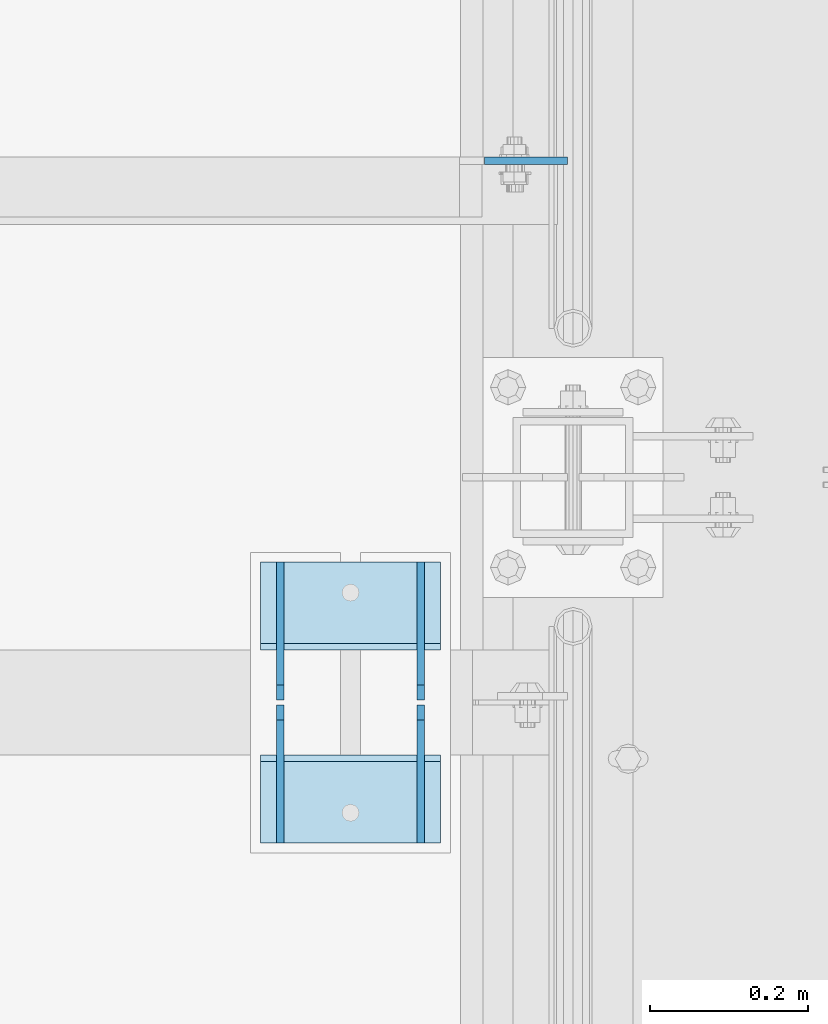
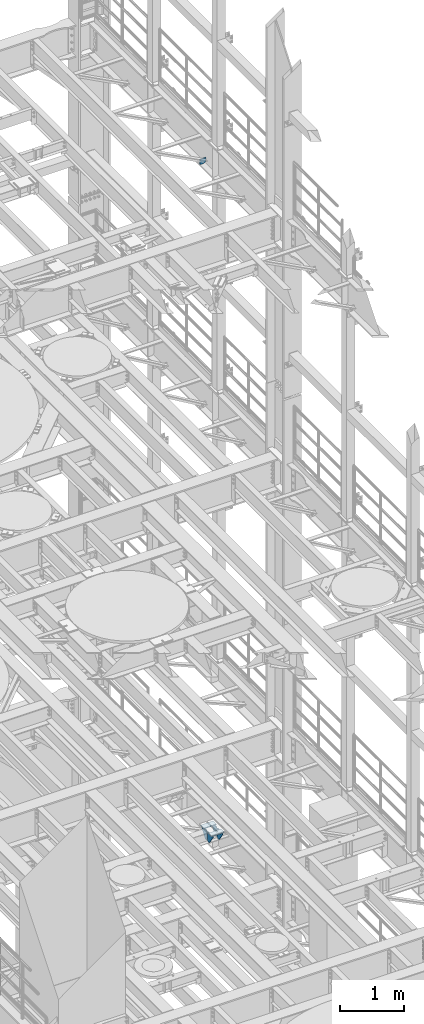
# One storey, part 1742 of 1876: 7 plates, 2 elements without a shape of their own.
"""IFC2X3 building model written with IfcOpenShell, lengths in millimetres."""

from ifc_helpers import new_model, si_unit, frame, origin_with_axes, place, context, subcontext, project, spatial, faceted_brep, material, type_object, element, aggregate, save


model = new_model("IFC2X3")

# Units and contexts
model_context = context("Model", 3, precision=1e-05, world=origin_with_axes())
body_context = subcontext(model_context, "Body", "Model", "MODEL_VIEW")
ifc_project = project(units=[si_unit("LENGTHUNIT", "METRE", prefix="MILLI"), si_unit("AREAUNIT", "SQUARE_METRE"), si_unit("VOLUMEUNIT", "CUBIC_METRE"), si_unit("MASSUNIT", "GRAM", prefix="KILO"), si_unit("TIMEUNIT", "SECOND"), si_unit("PLANEANGLEUNIT", "RADIAN"), si_unit("SOLIDANGLEUNIT", "STERADIAN"), si_unit("THERMODYNAMICTEMPERATUREUNIT", "DEGREE_CELSIUS"), si_unit("LUMINOUSINTENSITYUNIT", "LUMEN")], contexts=[model_context])

# Site, building, storey
site_placement = place(None, origin_with_axes())
site = spatial("IfcSite", under=ifc_project, at=site_placement, CompositionType="ELEMENT")
building_placement = place(site_placement, origin_with_axes())
building = spatial("IfcBuilding", under=site, at=building_placement, Name="Undefined", CompositionType="ELEMENT")
storey_placement = place(building_placement, origin_with_axes())
storey = spatial("IfcBuildingStorey", under=building, at=storey_placement, Name="Undefined", CompositionType="ELEMENT", Elevation=0.0)

# Assembly, plate
assembly_1_placement = place(storey_placement, origin_with_axes())
assembly_1 = element("IfcElementAssembly", 1, at=assembly_1_placement, inside=storey, Name="BEAM", AssemblyPlace="NOTDEFINED", PredefinedType="RIGID_FRAME")
ifc_material = material(Name="STEEL/A36")
plate_type_1 = type_object("IfcPlateType", PredefinedType="NOTDEFINED")
plate_1_placement = place(assembly_1_placement, frame((7612.85625000072, 10053.6375, 17386.2999999996), z_axis=(-1.0, 0.0, 0.0), x_axis=(0.0, 0.0, 1.0)))
plate_1 = element("IfcPlate", 2, at=plate_1_placement, type_object=plate_type_1, material=ifc_material, Name="PLATE", context=body_context, shape_type="Brep", body=[
    faceted_brep([(-9.76996261670138e-14, -4.76250000000073, 31.75), (0.0, -4.76249999999982, 105.281791687012), (0.0, 4.76249999999982, 105.281791687012), (-9.76996261670138e-14, 4.76250000000073, 31.75), (103.391876220703, -4.76249999999982, 105.281791687012), (103.391876220703, 4.76249999999982, 105.281791687012), (103.391876220703, -4.76249999999982, 0.0), (103.391876220703, 4.76249999999982, 0.0), (31.75, -4.76250000000073, 0.0), (31.75, 4.76250000000073, 0.0)], [[[0, 1, 2, 3]], [[1, 4, 5, 2]], [[4, 6, 7, 5]], [[6, 8, 9, 7]], [[8, 0, 3, 9]], [[5, 7, 9, 3, 2]], [[8, 6, 4, 1, 0]]]),
])
aggregate(assembly_1, [plate_1])

# Assembly, plates
assembly_2_placement = place(storey_placement, origin_with_axes())
assembly_2 = element("IfcElementAssembly", 3, at=assembly_2_placement, inside=storey, Name="BEAM", AssemblyPlace="NOTDEFINED", PredefinedType="RIGID_FRAME")
plate_type_2 = type_object("IfcPlateType", PredefinedType="NOTDEFINED")
plate_2_placement = place(assembly_2_placement, frame((7426.324160994, 9544.39104156494, 5122.862), z_axis=(0.0, -1.0, 0.0), x_axis=(0.0, 0.0, -1.0)))
plate_2 = element("IfcPlate", 4, at=plate_2_placement, type_object=plate_type_2, material=ifc_material, Name="PLATE", context=body_context, shape_type="Brep", body=[
    faceted_brep([(0.0, -4.76249999999982, 0.0), (-0.000445560885964369, -4.76249999999982, 155.916034698565), (-0.000445560885964369, 4.76249999999982, 155.916034698565), (0.0, 4.76249999999982, 0.0), (19.0494992370368, -4.76249999999982, 174.966033935547), (19.0494992370368, 4.76249999999982, 174.966033935547), (171.4494972229, -4.76249999999982, 174.966033935547), (171.4494972229, 4.76249999999982, 174.966033935547), (190.499496459961, -4.76249999999982, 155.916034698486), (190.499496459961, 4.76249999999982, 155.916034698486), (190.499496459961, -4.76249999999982, 111.466041564941), (190.499496459961, 4.76249999999982, 111.466041564941), (25.4000015258789, -4.76250000000073, 0.0), (25.4000015258789, 4.76250000000073, 0.0)], [[[0, 1, 2, 3]], [[1, 4, 5, 2]], [[4, 6, 7, 5]], [[6, 8, 9, 7]], [[8, 10, 11, 9]], [[10, 12, 13, 11]], [[12, 0, 3, 13]], [[5, 7, 9, 11, 13, 3, 2]], [[12, 10, 8, 6, 4, 1, 0]]]),
])
plate_3_placement = place(assembly_2_placement, frame((7248.524160994, 9544.39104156494, 5122.862), z_axis=(0.0, -1.0, 0.0), x_axis=(0.0, 0.0, -1.0)))
plate_3 = element("IfcPlate", 5, at=plate_3_placement, type_object=plate_type_2, material=ifc_material, Name="PLATE", context=body_context, shape_type="Brep", body=[
    faceted_brep([(0.0, -4.76249999999982, 0.0), (-0.000445560885964369, -4.76249999999982, 155.916034698565), (-0.000445560885964369, 4.76249999999982, 155.916034698565), (0.0, 4.76249999999982, 0.0), (19.0494992370368, -4.76249999999982, 174.966033935547), (19.0494992370368, 4.76249999999982, 174.966033935547), (171.4494972229, -4.76249999999982, 174.966033935547), (171.4494972229, 4.76249999999982, 174.966033935547), (190.499496459961, -4.76249999999982, 155.916034698486), (190.499496459961, 4.76249999999982, 155.916034698486), (190.499496459961, -4.76249999999982, 111.466041564941), (190.499496459961, 4.76249999999982, 111.466041564941), (25.4000015258789, -4.76250000000073, 0.0), (25.4000015258789, 4.76250000000073, 0.0)], [[[0, 1, 2, 3]], [[1, 4, 5, 2]], [[4, 6, 7, 5]], [[6, 8, 9, 7]], [[8, 10, 11, 9]], [[10, 12, 13, 11]], [[12, 0, 3, 13]], [[5, 7, 9, 11, 13, 3, 2]], [[12, 10, 8, 6, 4, 1, 0]]]),
])
plate_4_placement = place(assembly_2_placement, frame((7426.324160994, 9188.10895843506, 5122.862), z_axis=(0.0, 1.0, 0.0), x_axis=(0.0, 0.0, -1.0)))
plate_4 = element("IfcPlate", 6, at=plate_4_placement, type_object=plate_type_2, material=ifc_material, Name="PLATE", context=body_context, shape_type="Brep", body=[
    faceted_brep([(0.0, -4.76249999999982, 0.0), (-0.000445560885964369, -4.76249999999982, 155.916034698565), (-0.000445560885964369, 4.76249999999982, 155.916034698565), (0.0, 4.76249999999982, 0.0), (19.0494992370368, -4.76249999999982, 174.966033935547), (19.0494992370368, 4.76249999999982, 174.966033935547), (171.4494972229, -4.76249999999982, 174.966033935547), (171.4494972229, 4.76249999999982, 174.966033935547), (190.499496459961, -4.76249999999982, 155.916034698486), (190.499496459961, 4.76249999999982, 155.916034698486), (190.499496459961, -4.76249999999982, 111.466041564941), (190.499496459961, 4.76249999999982, 111.466041564941), (25.4000015258789, -4.76250000000073, 0.0), (25.4000015258789, 4.76250000000073, 0.0)], [[[0, 1, 2, 3]], [[1, 4, 5, 2]], [[4, 6, 7, 5]], [[6, 8, 9, 7]], [[8, 10, 11, 9]], [[10, 12, 13, 11]], [[12, 0, 3, 13]], [[5, 7, 9, 11, 13, 3, 2]], [[12, 10, 8, 6, 4, 1, 0]]]),
])
plate_5_placement = place(assembly_2_placement, frame((7248.524160994, 9188.10895843506, 5122.862), z_axis=(0.0, 1.0, 0.0), x_axis=(0.0, 0.0, -1.0)))
plate_5 = element("IfcPlate", 7, at=plate_5_placement, type_object=plate_type_2, material=ifc_material, Name="PLATE", context=body_context, shape_type="Brep", body=[
    faceted_brep([(0.0, -4.76249999999982, 0.0), (-0.000445560885964369, -4.76249999999982, 155.916034698565), (-0.000445560885964369, 4.76249999999982, 155.916034698565), (0.0, 4.76249999999982, 0.0), (19.0494992370368, -4.76249999999982, 174.966033935547), (19.0494992370368, 4.76249999999982, 174.966033935547), (171.4494972229, -4.76249999999982, 174.966033935547), (171.4494972229, 4.76249999999982, 174.966033935547), (190.499496459961, -4.76249999999982, 155.916034698486), (190.499496459961, 4.76249999999982, 155.916034698486), (190.499496459961, -4.76249999999982, 111.466041564941), (190.499496459961, 4.76249999999982, 111.466041564941), (25.4000015258789, -4.76250000000073, 0.0), (25.4000015258789, 4.76250000000073, 0.0)], [[[0, 1, 2, 3]], [[1, 4, 5, 2]], [[4, 6, 7, 5]], [[6, 8, 9, 7]], [[8, 10, 11, 9]], [[10, 12, 13, 11]], [[12, 0, 3, 13]], [[5, 7, 9, 11, 13, 3, 2]], [[12, 10, 8, 6, 4, 1, 0]]]),
])
plate_type_3 = type_object("IfcPlateType", PredefinedType="NOTDEFINED")
plate_6_placement = place(assembly_2_placement, frame((7223.12629417271, 9432.925, 5126.831), z_axis=(1.0, 0.0, 0.0), x_axis=(0.0, 1.0, 0.0)))
plate_6 = element("IfcPlate", 8, at=plate_6_placement, type_object=plate_type_3, material=ifc_material, Name="PLATE", context=body_context, shape_type="Brep", body=[
    faceted_brep([(111.466041564941, -3.96900000000005, 228.599548339844), (111.466041564941, -3.96900000000005, 0.0), (111.466041564941, 3.96900000000005, 0.0), (111.466041564941, 3.96900000000005, 228.599548339844), (7.93749999726606, 3.96900000000005, 228.599548339844), (0.0, -3.96900000000005, 228.599548339844), (0.0, -3.96900000000005, 0.0), (7.93749999726606, 3.96900000000005, 0.0)], [[[0, 1, 2, 3]], [[0, 3, 4, 5]], [[1, 0, 5, 6]], [[2, 1, 6, 7]], [[3, 2, 7, 4]], [[6, 5, 4, 7]]]),
])
plate_7_placement = place(assembly_2_placement, frame((7223.12629417271, 9299.575, 5126.831), z_axis=(1.0, 0.0, 0.0), x_axis=(0.0, -1.0, 0.0)))
plate_7 = element("IfcPlate", 9, at=plate_7_placement, type_object=plate_type_3, material=ifc_material, Name="PLATE", context=body_context, shape_type="Brep", body=[
    faceted_brep([(111.466041564941, -3.96900000000005, 228.599548339844), (111.466041564941, -3.96900000000005, 0.0), (111.466041564941, 3.96900000000005, 0.0), (111.466041564941, 3.96900000000005, 228.599548339844), (7.93749999726788, -3.96900000000005, 228.599548339844), (7.93749999726788, -3.96900000000005, 0.0), (0.0, 3.96900000000005, 0.0), (0.0, 3.96900000000005, 228.599548339844)], [[[0, 1, 2, 3]], [[1, 0, 4, 5]], [[2, 1, 5, 6]], [[3, 2, 6, 7]], [[0, 3, 7, 4]], [[6, 5, 4, 7]]]),
])
aggregate(assembly_2, [plate_2, plate_3, plate_6, plate_4, plate_5, plate_7])

save(model, "model.ifc")
